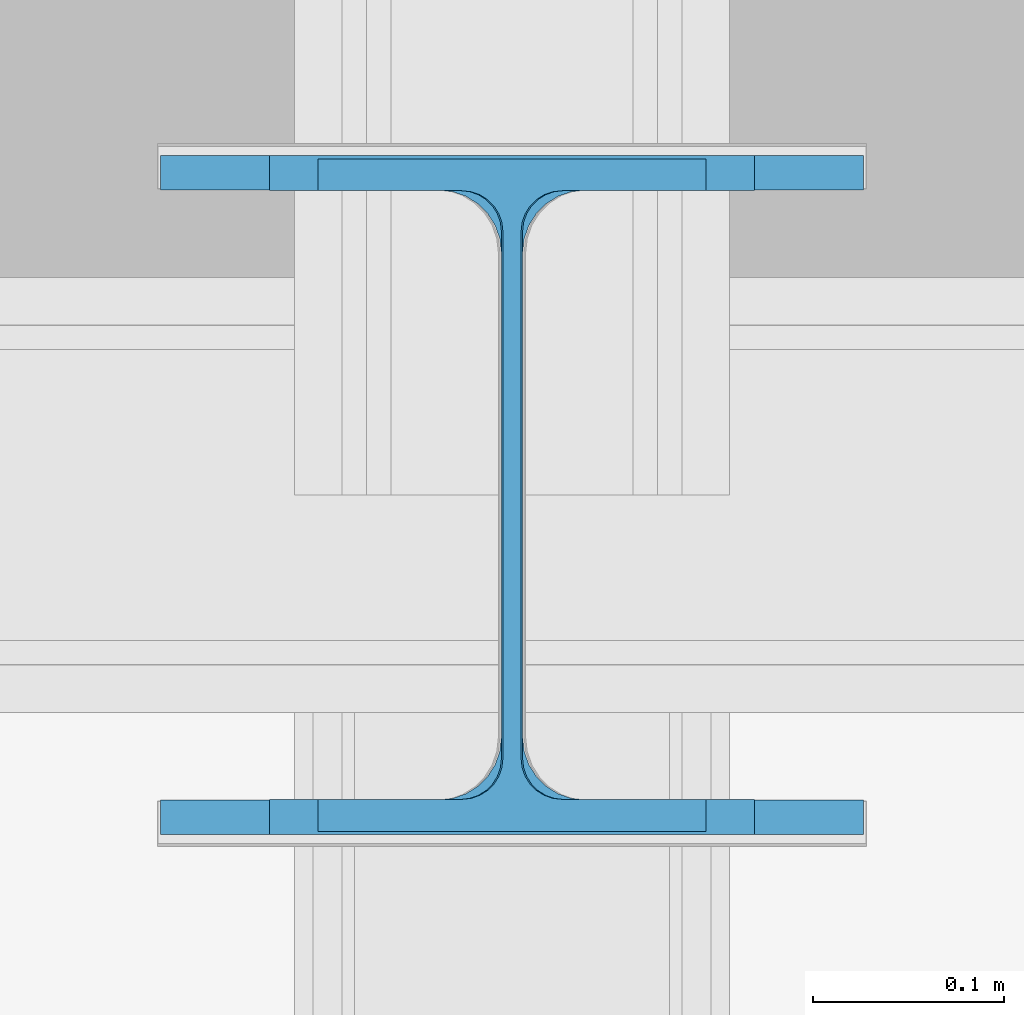
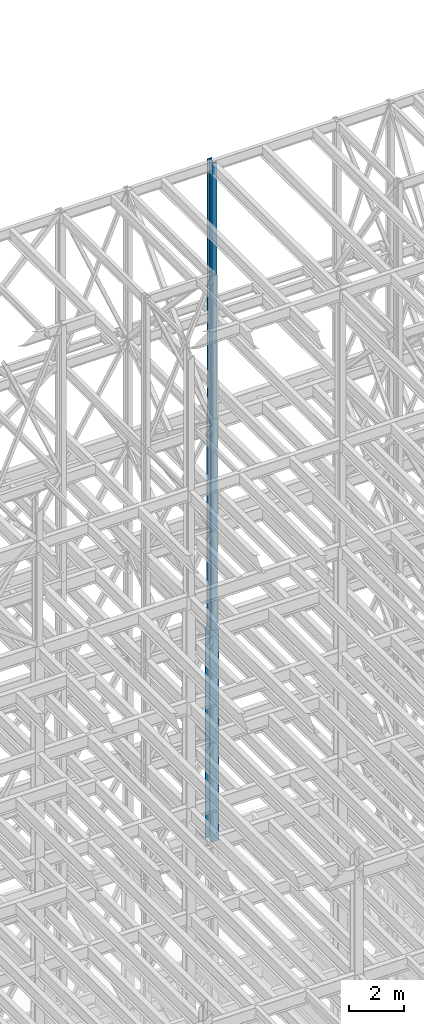
# One storey, part 100 of 150: 3 columns.
"""IFC2X3 building model written with IfcOpenShell, lengths in millimetres."""

import ifcopenshell
import ifcopenshell.guid

model = None  # the IFC model being written
_history = None  # IfcOwnerHistory: only IFC2X3 demands one
_inside = {}  # id of a spatial element -> (the spatial element, [elements in it])
_under = {}  # id of a project, library or spatial element -> (it, [spatial elements below it])
_declared = {}  # id of a project -> (the project, [libraries it declares])
_typed = {}  # id of a type object -> (the type object, [elements of that type])
_made_of = {}  # id of a material, layer set ... -> (it, [elements and type objects made of it])


def new_model(schema):
    """Start an empty IFC model of exactly this schema.

    Asked for "IFC4X3", IfcOpenShell would pick the latest addendum, in which some entities
    have other attributes; the version numbers below select the first issue.
    IFC2X3 requires an IfcOwnerHistory on every rooted entity: one is made here for all.
    """
    global model, _history
    if schema == "IFC4X3":
        model = ifcopenshell.file(schema_version=(4, 3, 0, 0))
    else:
        model = ifcopenshell.file(schema=schema)
    _inside.clear()
    _under.clear()
    _declared.clear()
    _typed.clear()
    _made_of.clear()
    _history = None
    if model.schema == "IFC2X3":
        org = make("IfcOrganization", Name="unknown")
        user = make(
            "IfcPersonAndOrganization",
            ThePerson=make("IfcPerson", FamilyName="unknown"),
            TheOrganization=org,
        )
        app = make(
            "IfcApplication",
            ApplicationDeveloper=org,
            Version="unknown",
            ApplicationFullName="unknown",
            ApplicationIdentifier="unknown",
        )
        _history = make(
            "IfcOwnerHistory",
            OwningUser=user,
            OwningApplication=app,
            ChangeAction="ADDED",
            CreationDate=0,
        )
    return model


def make(cls, **values):
    """One entity of the class cls with the attributes given. An attribute that is None is left unset."""
    return model.create_entity(
        cls, **{name: value for name, value in values.items() if value is not None}
    )


def rooted(cls, **values):
    """An entity with a GlobalId (a new one), such as an element, a storey or a relation."""
    return make(cls, GlobalId=ifcopenshell.guid.new(), OwnerHistory=_history, **values)


def si_unit(unit_type, name, prefix=None):
    """IfcSIUnit, for example si_unit("LENGTHUNIT", "METRE", prefix="MILLI")."""
    return make("IfcSIUnit", UnitType=unit_type, Prefix=prefix, Name=name)


def assignment(units):
    """IfcUnitAssignment: the units of a project."""
    return None if units is None else make("IfcUnitAssignment", Units=units)


def point(xyz):
    """IfcCartesianPoint."""
    return None if xyz is None else make("IfcCartesianPoint", Coordinates=xyz)


def direction(xyz):
    """IfcDirection."""
    return None if xyz is None else make("IfcDirection", DirectionRatios=xyz)


def frame(location, z_axis=None, x_axis=None):
    """IfcAxis2Placement3D, a coordinate frame: its origin and axes. An axis left out is left unset."""
    return make(
        "IfcAxis2Placement3D",
        Location=point(location),
        Axis=direction(z_axis),
        RefDirection=direction(x_axis),
    )


def frame_2d(location, x_axis=None):
    """IfcAxis2Placement2D, a coordinate frame in the plane: its origin and x axis."""
    return make(
        "IfcAxis2Placement2D", Location=point(location), RefDirection=direction(x_axis)
    )


def origin_with_axes():
    """The frame at (0, 0, 0) with the z axis (0, 0, 1) and the x axis (1, 0, 0) written out."""
    return frame((0.0, 0.0, 0.0), z_axis=(0.0, 0.0, 1.0), x_axis=(1.0, 0.0, 0.0))


def origin_2d_with_axis():
    """The frame at (0, 0) in the plane with the x axis (1, 0) written out."""
    return frame_2d((0.0, 0.0), x_axis=(1.0, 0.0))


def place(relative_to, where):
    """IfcLocalPlacement: puts the frame where relative to a parent placement (None: the world)."""
    return make(
        "IfcLocalPlacement", PlacementRelTo=relative_to, RelativePlacement=where
    )


def context(
    kind, dimensions, precision=None, world=None, true_north=None, identifier=None
):
    """IfcGeometricRepresentationContext, for example the 3D "Model" context."""
    return make(
        "IfcGeometricRepresentationContext",
        ContextIdentifier=identifier,
        ContextType=kind,
        CoordinateSpaceDimension=dimensions,
        Precision=precision,
        WorldCoordinateSystem=world,
        TrueNorth=true_north,
    )


def subcontext(parent, identifier, kind, view, scale=None):
    """IfcGeometricRepresentationSubContext, for example "Body" below "Model"."""
    return make(
        "IfcGeometricRepresentationSubContext",
        ContextIdentifier=identifier,
        ContextType=kind,
        ParentContext=parent,
        TargetScale=scale,
        TargetView=view,
    )


def project(units=None, contexts=None):
    """IfcProject with its units and contexts."""
    return rooted(
        "IfcProject",
        Name="project",
        RepresentationContexts=contexts,
        UnitsInContext=assignment(units),
    )


def spatial(cls, under=None, at=None, **own):
    """A site, building, storey or space (cls), placed at a placement, below another one or the project."""
    s = rooted(cls, ObjectPlacement=at, **own)
    if under is not None:
        _under.setdefault(under.id(), (under, []))[1].append(s)
    return s


def profile(cls, at=None, kind="AREA", **sizes):
    """A parametric profile (cls). Its sizes go by their IFC names, for example OverallWidth=200.0."""
    return make(cls, ProfileType=kind, Position=at, **sizes)


def i_section(**sizes):
    """IfcIShapeProfileDef."""
    return profile("IfcIShapeProfileDef", **sizes)


def extrude(swept, where, along, depth):
    """IfcExtrudedAreaSolid: the profile swept, set in the frame where, extruded along a direction by depth."""
    return make(
        "IfcExtrudedAreaSolid",
        SweptArea=swept,
        Position=where,
        ExtrudedDirection=direction(along),
        Depth=depth,
    )


def shape(context_of_items, identifier, shape_type, items):
    """IfcShapeRepresentation: the items that make up one representation, for example the "Body"."""
    return make(
        "IfcShapeRepresentation",
        ContextOfItems=context_of_items,
        RepresentationIdentifier=identifier,
        RepresentationType=shape_type,
        Items=items,
    )


def material(Name=None, Category=None):
    """IfcMaterial."""
    return make("IfcMaterial", Name=Name, Category=Category)


def made_of(thing, what):
    """Note that an element or type object is made of a material, layer set ...; save() writes the relation."""
    if what is not None:
        _made_of.setdefault(what.id(), (what, []))[1].append(thing)
    return thing


def type_object(cls, material=None, **own):
    """A type object (cls), such as IfcWallType, which elements share."""
    return made_of(rooted(cls, **own), material)


def element(
    cls,
    number,
    at=None,
    inside=None,
    cuts=None,
    type_object=None,
    material=None,
    context=None,
    identifier="Body",
    shape_type=None,
    held_by="IfcProductDefinitionShape",
    body=None,
    shapes=None,
    **own,
):
    """One element of the class cls, such as IfcWall. Its Tag is "e" and its number.

    at: its placement. inside: the storey or other place that contains it. cuts: it is an
    opening in that element (IfcRelVoidsElement). A single representation is given by context,
    identifier, shape_type and body (its items); several are given by shapes. held_by: the class
    of the entity that holds the representations. save() writes the other relations.
    """
    e = rooted(cls, Tag="e%d" % number, ObjectPlacement=at, **own)
    if body is not None:
        shapes = [shape(context, identifier, shape_type, body)]
    if shapes is not None:
        e.Representation = make(held_by, Representations=shapes)
    if inside is not None:
        _inside.setdefault(inside.id(), (inside, []))[1].append(e)
    if cuts is not None:
        rooted(
            "IfcRelVoidsElement", RelatingBuildingElement=cuts, RelatedOpeningElement=e
        )
    if type_object is not None:
        _typed.setdefault(type_object.id(), (type_object, []))[1].append(e)
    return made_of(e, material)


def aggregate(whole, parts):
    """IfcRelAggregates: a whole, such as a stair, and the parts it consists of."""
    return rooted("IfcRelAggregates", RelatingObject=whole, RelatedObjects=parts)


def save(model, path):
    """Write the relations noted so far, then the file.

    IfcRelAggregates (storeys below a building ...), IfcRelContainedInSpatialStructure (elements
    in a storey), IfcRelDefinesByType, IfcRelAssociatesMaterial and IfcRelDeclares: one each for
    every whole, place, type object, material and project.
    """
    for whole, parts in _under.values():
        aggregate(whole, parts)
    for where, things in _inside.values():
        rooted(
            "IfcRelContainedInSpatialStructure",
            RelatedElements=things,
            RelatingStructure=where,
        )
    for kind, things in _typed.values():
        rooted("IfcRelDefinesByType", RelatedObjects=things, RelatingType=kind)
    for what, things in _made_of.values():
        rooted("IfcRelAssociatesMaterial", RelatedObjects=things, RelatingMaterial=what)
    for by, libraries in _declared.values():
        rooted("IfcRelDeclares", RelatingContext=by, RelatedDefinitions=libraries)
    model.write(path)


model = new_model("IFC2X3")

# Units and contexts
model_context = context("Model", 3, precision=1e-05, world=origin_with_axes())
body_context = subcontext(model_context, "Body", "Model", "MODEL_VIEW")
ifc_project = project(units=[si_unit("LENGTHUNIT", "METRE", prefix="MILLI"), si_unit("AREAUNIT", "SQUARE_METRE"), si_unit("VOLUMEUNIT", "CUBIC_METRE"), si_unit("MASSUNIT", "GRAM", prefix="KILO"), si_unit("TIMEUNIT", "SECOND"), si_unit("PLANEANGLEUNIT", "RADIAN"), si_unit("SOLIDANGLEUNIT", "STERADIAN"), si_unit("THERMODYNAMICTEMPERATUREUNIT", "DEGREE_CELSIUS"), si_unit("LUMINOUSINTENSITYUNIT", "LUMEN")], contexts=[model_context])

# Site, building, storey
site_placement = place(None, origin_with_axes())
site = spatial("IfcSite", under=ifc_project, at=site_placement, CompositionType="ELEMENT")
building_placement = place(site_placement, origin_with_axes())
building = spatial("IfcBuilding", under=site, at=building_placement, Name="Undefined", CompositionType="ELEMENT")
storey_placement = place(building_placement, origin_with_axes())
storey = spatial("IfcBuildingStorey", under=building, at=storey_placement, Name="Undefined", CompositionType="ELEMENT", Elevation=0.0)

# Columns
ifc_material = material(Name="STEEL/A992")
column_type_1 = type_object("IfcColumnType", Name="W14X53", PredefinedType="NOTDEFINED")
column_1_placement = place(storey_placement, frame((69392.8, 31877.0, 54483.0), z_axis=(0.0, 0.0, 1.0), x_axis=(1.0, 0.0, 0.0)))
element("IfcColumn", 1, at=column_1_placement, inside=storey, type_object=column_type_1, material=ifc_material, Name="COLUMN", ObjectType="W14X53", context=body_context, shape_type="SweptSolid", body=[
    extrude(i_section(OverallWidth=203.2, OverallDepth=352.425, WebThickness=9.5249, FlangeThickness=16.764, FilletRadius=21.336, at=origin_2d_with_axis()), frame((0.0, 0.0, 11430.0), z_axis=(0.0, 0.0, -1.0), x_axis=(-1.0, 0.0, 0.0)), (0.0, 0.0, 1.0), 11430.0),
])
column_type_2 = type_object("IfcColumnType", Name="W14X68", PredefinedType="NOTDEFINED")
column_2_placement = place(storey_placement, frame((69392.8, 31877.0, 45034.2), z_axis=(0.0, 0.0, 1.0), x_axis=(1.0, 0.0, 0.0)))
element("IfcColumn", 2, at=column_2_placement, inside=storey, type_object=column_type_2, material=ifc_material, Name="COLUMN", ObjectType="W14X68", context=body_context, shape_type="SweptSolid", body=[
    extrude(i_section(OverallWidth=254.0, OverallDepth=355.6, WebThickness=11.1125, FlangeThickness=18.288, FilletRadius=21.3994, at=origin_2d_with_axis()), frame((0.0, 0.0, 9448.8), z_axis=(0.0, 0.0, -1.0), x_axis=(-1.0, 0.0, 0.0)), (0.0, 0.0, 1.0), 9448.8),
])
column_type_3 = type_object("IfcColumnType", Name="W14X90", PredefinedType="NOTDEFINED")
column_3_placement = place(storey_placement, frame((69392.8, 31877.0, 35585.4), z_axis=(0.0, 0.0, 1.0), x_axis=(1.0, 0.0, 0.0)))
element("IfcColumn", 3, at=column_3_placement, inside=storey, type_object=column_type_3, material=ifc_material, Name="COLUMN", ObjectType="W14X90", context=body_context, shape_type="SweptSolid", body=[
    extrude(i_section(OverallWidth=368.3, OverallDepth=355.6, WebThickness=11.1125, FlangeThickness=18.034, FilletRadius=32.7659, at=origin_2d_with_axis()), frame((0.0, 0.0, 9448.8), z_axis=(0.0, 0.0, -1.0), x_axis=(-1.0, 0.0, 0.0)), (0.0, 0.0, 1.0), 9448.79999999999),
])

save(model, "model.ifc")
